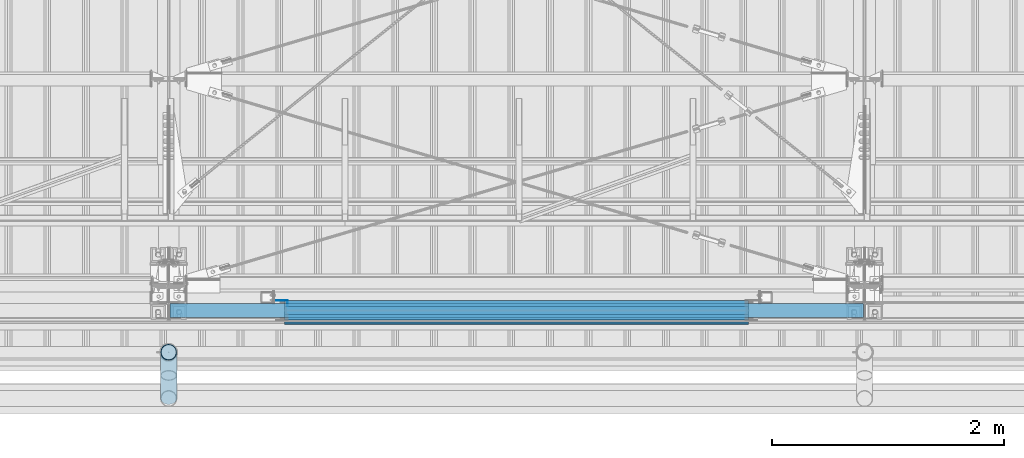
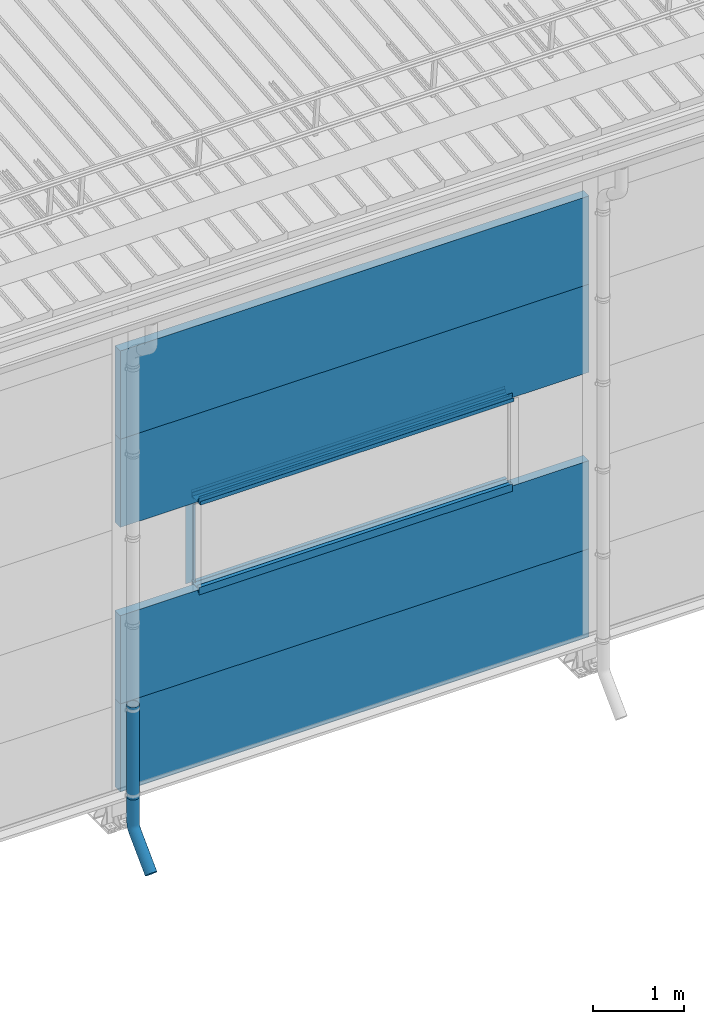
# One storey, part 30 of 709: 14 beams, 14 elements without a shape of their own.
"""IFC4 building model written with IfcOpenShell, lengths in millimetres."""

from ifc_helpers import new_model, entity, si_unit, direction, frame, origin_with_axes, place, context, subcontext, project, spatial, line, indexed_curve, outline, extrude, material, element, aggregate, save


model = new_model("IFC4")

# Units and contexts
model_context = context("Model", 3, precision=0.2, world=origin_with_axes(), true_north=direction((0.0, 1.0)))
body_context = subcontext(model_context, "Body", "Model", "MODEL_VIEW")
ifc_project = project(units=[si_unit("LENGTHUNIT", "METRE", prefix="MILLI"), si_unit("AREAUNIT", "SQUARE_METRE"), si_unit("VOLUMEUNIT", "CUBIC_METRE"), si_unit("MASSUNIT", "GRAM", prefix="KILO"), si_unit("TIMEUNIT", "SECOND"), si_unit("PLANEANGLEUNIT", "RADIAN"), si_unit("SOLIDANGLEUNIT", "STERADIAN"), si_unit("THERMODYNAMICTEMPERATUREUNIT", "DEGREE_CELSIUS"), si_unit("LUMINOUSINTENSITYUNIT", "LUMEN")], contexts=[model_context])

# Site, building, storey
site_placement = place(None, origin_with_axes())
site = spatial("IfcSite", under=ifc_project, at=site_placement, CompositionType="ELEMENT")
building_placement = place(site_placement, origin_with_axes())
building = spatial("IfcBuilding", under=site, at=building_placement, Name="Undefined", CompositionType="ELEMENT")
storey_placement = place(building_placement, origin_with_axes())
storey = spatial("IfcBuildingStorey", under=building, at=storey_placement, Name="Undefined", CompositionType="ELEMENT", Elevation=0.0)

# Assembly, beam
assembly_1_placement = place(storey_placement, frame((4010.0, -60.0, 895.0), z_axis=(0.0, 0.0, -1.0), x_axis=(1.0, 0.0, 0.0)))
assembly_1 = element("IfcElementAssembly", 1, at=assembly_1_placement, inside=storey)
ifc_material_1 = material(Name="Insulation", Category="Insulation")
beam_1_placement = place(assembly_1_placement, origin_with_axes())
beam_1 = element("IfcBeam", 2, at=beam_1_placement, material=ifc_material_1, ObjectType="P-107", context=body_context, shape_type="SolidModel", body=[
    extrude(outline(indexed_curve([(-595.0, -60.0), (595.0, -60.0), (595.0, 60.0), (-595.0, 60.0)], segments=[line(1, 2, 3, 4, 1)])), frame((0.0, 0.0, 0.0), z_axis=(-1.0, 0.0, 0.0), x_axis=(0.0, 0.0, 1.0)), (0.0, 0.0, -1.0), 5980.0),
])
aggregate(assembly_1, [beam_1])

assembly_2_placement = place(storey_placement, frame((4010.0, -60.0, 2085.0), z_axis=(0.0, 0.0, -1.0), x_axis=(1.0, 0.0, 0.0)))
assembly_2 = element("IfcElementAssembly", 3, at=assembly_2_placement, inside=storey)
beam_2_placement = place(assembly_2_placement, origin_with_axes())
beam_2 = element("IfcBeam", 4, at=beam_2_placement, material=ifc_material_1, ObjectType="P-107", context=body_context, shape_type="SolidModel", body=[
    extrude(outline(indexed_curve([(-595.0, -60.0), (595.0, -60.0), (595.0, 60.0), (-595.0, 60.0)], segments=[line(1, 2, 3, 4, 1)])), frame((0.0, 0.0, 0.0), z_axis=(-1.0, 0.0, 0.0), x_axis=(0.0, 0.0, 1.0)), (0.0, 0.0, -1.0), 5980.0),
])
aggregate(assembly_2, [beam_2])

assembly_3_placement = place(storey_placement, frame((4010.0, -60.0, 4465.0), z_axis=(0.0, 0.0, -1.0), x_axis=(1.0, 0.0, 0.0)))
assembly_3 = element("IfcElementAssembly", 5, at=assembly_3_placement, inside=storey)
beam_3_placement = place(assembly_3_placement, origin_with_axes())
beam_3 = element("IfcBeam", 6, at=beam_3_placement, material=ifc_material_1, ObjectType="P-107", context=body_context, shape_type="SolidModel", body=[
    extrude(outline(indexed_curve([(-595.0, -60.0), (595.0, -60.0), (595.0, 60.0), (-595.0, 60.0)], segments=[line(1, 2, 3, 4, 1)])), frame((0.0, 0.0, 0.0), z_axis=(-1.0, 0.0, 0.0), x_axis=(0.0, 0.0, 1.0)), (0.0, 0.0, -1.0), 5980.0),
])
aggregate(assembly_3, [beam_3])

assembly_4_placement = place(storey_placement, frame((4010.0, -60.0, 5655.0), z_axis=(0.0, 0.0, -1.0), x_axis=(1.0, 0.0, 0.0)))
assembly_4 = element("IfcElementAssembly", 7, at=assembly_4_placement, inside=storey)
beam_4_placement = place(assembly_4_placement, origin_with_axes())
beam_4 = element("IfcBeam", 8, at=beam_4_placement, material=ifc_material_1, ObjectType="P-107", context=body_context, shape_type="SolidModel", body=[
    extrude(outline(indexed_curve([(-595.0, -60.0), (595.0, -60.0), (595.0, 60.0), (-595.0, 60.0)], segments=[line(1, 2, 3, 4, 1)])), frame((0.0, 0.0, 0.0), z_axis=(-1.0, 0.0, 0.0), x_axis=(0.0, 0.0, 1.0)), (0.0, 0.0, -1.0), 5980.0),
])
aggregate(assembly_4, [beam_4])

assembly_5_placement = place(storey_placement, frame((5000.0, 1.0, 2725.0), z_axis=(0.0, 1.0, 0.0), x_axis=(1.0, 0.0, 0.0)))
assembly_5 = element("IfcElementAssembly", 9, at=assembly_5_placement, inside=storey)
ifc_material_2 = material(Name="Steel_Undefined", Category="STEEL")
beam_5_placement = place(assembly_5_placement, origin_with_axes())
beam_5 = element("IfcBeam", 10, at=beam_5_placement, material=ifc_material_2, context=body_context, shape_type="SolidModel", body=[
    extrude(outline(indexed_curve([(-25.0, -1.0), (25.0, -1.0), (25.0, 99.0), (23.0, 99.0), (23.0, 1.0), (-25.0, 1.0)], segments=[line(1, 2, 3, 4, 5, 6, 1)])), frame((0.0, 0.0, 0.0), z_axis=(-1.0, 0.0, 0.0), x_axis=(0.0, 0.0, 1.0)), (0.0, 0.0, -1.0), 4000.0),
])
aggregate(assembly_5, [beam_5])

assembly_6_placement = place(storey_placement, frame((9000.0, -60.0, 2680.0), z_axis=(0.0, 1.0, 0.0), x_axis=(-1.0, 0.0, 0.0)))
assembly_6 = element("IfcElementAssembly", 11, at=assembly_6_placement, inside=storey)
beam_6_placement = place(assembly_6_placement, origin_with_axes())
beam_6 = element("IfcBeam", 12, at=beam_6_placement, material=ifc_material_2, context=body_context, shape_type="SolidModel", body=[
    extrude(outline(indexed_curve([(-70.0, -25.0), (-68.0, -25.0), (-68.0, 23.0), (68.0, 23.0), (68.0, -25.0), (70.0, -25.0), (70.0, 25.0), (-70.0, 25.0)], segments=[line(1, 2, 3, 4, 5, 6, 7, 8, 1)])), frame((0.0, 0.0, 0.0), z_axis=(-1.0, 0.0, 0.0), x_axis=(0.0, 0.0, 1.0)), (0.0, 0.0, -1.0), 4000.0),
])
aggregate(assembly_6, [beam_6])

assembly_7_placement = place(storey_placement, frame((9000.0, -119.0, 2725.0), z_axis=(0.0, -1.0, 0.0), x_axis=(-1.0, 0.0, 0.0)))
assembly_7 = element("IfcElementAssembly", 13, at=assembly_7_placement, inside=storey)
beam_7_placement = place(assembly_7_placement, origin_with_axes())
beam_7 = element("IfcBeam", 14, at=beam_7_placement, material=ifc_material_2, context=body_context, shape_type="SolidModel", body=[
    extrude(outline(indexed_curve([(-25.0, -1.0), (25.0, -1.0), (25.0, 99.0), (23.0, 99.0), (23.0, 1.0), (-25.0, 1.0)], segments=[line(1, 2, 3, 4, 5, 6, 1)])), frame((0.0, 0.0, 0.0), z_axis=(-1.0, 0.0, 0.0), x_axis=(0.0, 0.0, 1.0)), (0.0, 0.0, -1.0), 4000.0),
])
aggregate(assembly_7, [beam_7])

assembly_8_placement = place(storey_placement, frame((9000.0, 1.0, 3845.0), z_axis=(0.0, 1.0, 0.0), x_axis=(-1.0, 0.0, 0.0)))
assembly_8 = element("IfcElementAssembly", 15, at=assembly_8_placement, inside=storey)
beam_8_placement = place(assembly_8_placement, origin_with_axes())
beam_8 = element("IfcBeam", 16, at=beam_8_placement, material=ifc_material_2, context=body_context, shape_type="SolidModel", body=[
    extrude(outline(indexed_curve([(-25.0, -1.0), (25.0, -1.0), (25.0, 99.0), (23.0, 99.0), (23.0, 1.0), (-25.0, 1.0)], segments=[line(1, 2, 3, 4, 5, 6, 1)])), frame((0.0, 0.0, 0.0), z_axis=(-1.0, 0.0, 0.0), x_axis=(0.0, 0.0, 1.0)), (0.0, 0.0, -1.0), 4000.0),
])
aggregate(assembly_8, [beam_8])

assembly_9_placement = place(storey_placement, frame((5000.0, -60.0, 3890.0), z_axis=(0.0, 1.0, 0.0), x_axis=(1.0, 0.0, 0.0)))
assembly_9 = element("IfcElementAssembly", 17, at=assembly_9_placement, inside=storey)
beam_9_placement = place(assembly_9_placement, origin_with_axes())
beam_9 = element("IfcBeam", 18, at=beam_9_placement, material=ifc_material_2, context=body_context, shape_type="SolidModel", body=[
    extrude(outline(indexed_curve([(-70.0, -25.0), (-68.0, -25.0), (-68.0, 23.0), (68.0, 23.0), (68.0, -25.0), (70.0, -25.0), (70.0, 25.0), (-70.0, 25.0)], segments=[line(1, 2, 3, 4, 5, 6, 7, 8, 1)])), frame((0.0, 0.0, 0.0), z_axis=(-1.0, 0.0, 0.0), x_axis=(0.0, 0.0, 1.0)), (0.0, 0.0, -1.0), 4000.0),
])
aggregate(assembly_9, [beam_9])

assembly_10_placement = place(storey_placement, frame((5000.0, -119.0, 3855.0), z_axis=(0.0, -1.0, 0.0), x_axis=(1.0, 0.0, 0.0)))
assembly_10 = element("IfcElementAssembly", 19, at=assembly_10_placement, inside=storey)
beam_10_placement = place(assembly_10_placement, origin_with_axes())
beam_10 = element("IfcBeam", 20, at=beam_10_placement, material=ifc_material_2, context=body_context, shape_type="SolidModel", body=[
    extrude(outline(indexed_curve([(-25.0, -1.0), (25.0, -1.0), (25.0, 99.0), (23.0, 99.0), (23.0, 1.0), (-25.0, 1.0)], segments=[line(1, 2, 3, 4, 5, 6, 1)])), frame((0.0, 0.0, 0.0), z_axis=(-1.0, 0.0, 0.0), x_axis=(0.0, 0.0, 1.0)), (0.0, 0.0, -1.0), 4000.0),
])
aggregate(assembly_10, [beam_10])

assembly_11_placement = place(storey_placement, frame((5000.0, -169.0, 3860.0), z_axis=(0.0, -1.0, 0.0), x_axis=(1.0, 0.0, 0.0)))
assembly_11 = element("IfcElementAssembly", 21, at=assembly_11_placement, inside=storey)
beam_11_placement = place(assembly_11_placement, origin_with_axes())
beam_11 = element("IfcBeam", 22, at=beam_11_placement, material=ifc_material_2, context=body_context, shape_type="SolidModel", body=[
    extrude(outline(indexed_curve([(-10.0, -1.0), (10.0, -1.0), (10.0, 49.0), (8.0, 49.0), (8.0, 1.0), (-10.0, 1.0)], segments=[line(1, 2, 3, 4, 5, 6, 1)])), frame((0.0, 0.0, 0.0), z_axis=(-1.0, 0.0, 0.0), x_axis=(0.0, 0.0, 1.0)), (0.0, 0.0, -1.0), 4000.0),
])
aggregate(assembly_11, [beam_11])

assembly_12_placement = place(storey_placement, frame((5025.0, 1.0, 3870.0), z_axis=(0.0, 1.0, 0.0), x_axis=(0.0, 0.0, -1.0)))
assembly_12 = element("IfcElementAssembly", 23, at=assembly_12_placement, inside=storey)
beam_12_placement = place(assembly_12_placement, origin_with_axes())
beam_12 = element("IfcBeam", 24, at=beam_12_placement, material=ifc_material_2, context=body_context, shape_type="SolidModel", body=[
    extrude(outline(indexed_curve([(-25.0, -1.0), (25.0, -1.0), (25.0, 99.0), (23.0, 99.0), (23.0, 1.0), (-25.0, 1.0)], segments=[line(1, 2, 3, 4, 5, 6, 1)])), frame((0.0, 0.0, 0.0), z_axis=(-1.0, 0.0, 0.0), x_axis=(0.0, 0.0, 1.0)), (0.0, 0.0, -1.0), 1170.0),
])
aggregate(assembly_12, [beam_12])

assembly_13_placement = place(storey_placement, frame((4000.0, -420.0, 1676.92297), z_axis=(0.0, 1.0, 0.0), x_axis=(0.0, 0.0, -1.0)))
assembly_13 = element("IfcElementAssembly", 25, at=assembly_13_placement, inside=storey)
beam_13_placement = place(assembly_13_placement, origin_with_axes())
beam_13 = element("IfcBeam", 26, at=beam_13_placement, material=ifc_material_2, ObjectType="614", context=body_context, shape_type="SolidModel", body=[
    extrude(outline(indexed_curve([(70.0, 0.0), (69.61653, 7.31699), (68.47033, 14.55382), (66.57396, 21.63119), (63.94818, 28.47157), (60.62178, 35.0), (56.63119, 41.14497), (52.02014, 46.83914), (46.83914, 52.02014), (41.14497, 56.63119), (35.0, 60.62178), (28.47157, 63.94818), (21.63119, 66.57396), (14.55382, 68.47033), (7.31699, 69.61653), (0.0, 70.0), (-7.31699, 69.61653), (-14.55382, 68.47033), (-21.63119, 66.57396), (-28.47157, 63.94818), (-35.0, 60.62178), (-41.14497, 56.63119), (-46.83914, 52.02014), (-52.02014, 46.83914), (-56.63119, 41.14497), (-60.62178, 35.0), (-63.94818, 28.47157), (-66.57396, 21.63119), (-68.47033, 14.55382), (-69.61653, 7.31699), (-70.0, 0.0), (-69.61653, -7.31699), (-68.47033, -14.55382), (-66.57396, -21.63119), (-63.94818, -28.47157), (-60.62178, -35.0), (-56.63119, -41.14497), (-52.02014, -46.83914), (-46.83914, -52.02014), (-41.14497, -56.63119), (-35.0, -60.62178), (-28.47157, -63.94818), (-21.63119, -66.57396), (-14.55382, -68.47033), (-7.31699, -69.61653), (0.0, -70.0), (7.31699, -69.61653), (14.55382, -68.47033), (21.63119, -66.57396), (28.47157, -63.94818), (35.0, -60.62178), (41.14497, -56.63119), (46.83914, -52.02014), (52.02014, -46.83914), (56.63119, -41.14497), (60.62178, -35.0), (63.94818, -28.47157), (66.57396, -21.63119), (68.47033, -14.55382), (69.61653, -7.31699)], segments=[line(1, 2, 3, 4, 5, 6, 7, 8, 9, 10, 11, 12, 13, 14, 15, 16, 17, 18, 19, 20, 21, 22, 23, 24, 25, 26, 27, 28, 29, 30, 31, 32, 33, 34, 35, 36, 37, 38, 39, 40, 41, 42, 43, 44, 45, 46, 47, 48, 49, 50, 51, 52, 53, 54, 55, 56, 57, 58, 59, 60, 1)]), holes=[indexed_curve([(65.0, 0.0), (64.64392, -6.79435), (63.57959, -13.51426), (61.81867, -20.0861), (59.38045, -26.43788), (56.29165, -32.5), (52.5861, -38.20604), (48.30441, -43.49349), (43.49349, -48.30441), (38.20604, -52.5861), (32.5, -56.29165), (26.43788, -59.38045), (20.0861, -61.81867), (13.51426, -63.57959), (6.79435, -64.64392), (0.0, -65.0), (-6.79435, -64.64392), (-13.51426, -63.57959), (-20.0861, -61.81867), (-26.43788, -59.38045), (-32.5, -56.29165), (-38.20604, -52.5861), (-43.49349, -48.30441), (-48.30441, -43.49349), (-52.5861, -38.20604), (-56.29165, -32.5), (-59.38045, -26.43788), (-61.81867, -20.0861), (-63.57959, -13.51426), (-64.64392, -6.79435), (-65.0, 0.0), (-64.64392, 6.79435), (-63.57959, 13.51426), (-61.81867, 20.0861), (-59.38045, 26.43788), (-56.29165, 32.5), (-52.5861, 38.20604), (-48.30441, 43.49349), (-43.49349, 48.30441), (-38.20604, 52.5861), (-32.5, 56.29165), (-26.43788, 59.38045), (-20.0861, 61.81867), (-13.51426, 63.57959), (-6.79435, 64.64392), (0.0, 65.0), (6.79435, 64.64392), (13.51426, 63.57959), (20.0861, 61.81867), (26.43788, 59.38045), (32.5, 56.29165), (38.20604, 52.5861), (43.49349, 48.30441), (48.30441, 43.49349), (52.5861, 38.20604), (56.29165, 32.5), (59.38045, 26.43788), (61.81867, 20.0861), (63.57959, 13.51426), (64.64392, 6.79435)], segments=[line(1, 2, 3, 4, 5, 6, 7, 8, 9, 10, 11, 12, 13, 14, 15, 16, 17, 18, 19, 20, 21, 22, 23, 24, 25, 26, 27, 28, 29, 30, 31, 32, 33, 34, 35, 36, 37, 38, 39, 40, 41, 42, 43, 44, 45, 46, 47, 48, 49, 50, 51, 52, 53, 54, 55, 56, 57, 58, 59, 60, 1)])]), frame((0.0, 0.0, 0.0), z_axis=(-1.0, 0.0, 0.0), x_axis=(0.0, 0.0, 1.0)), (0.0, 0.0, -1.0), 1250.0),
])
aggregate(assembly_13, [beam_13])

assembly_14_placement = place(storey_placement, frame((4000.0, -420.0, 526.92297), z_axis=(-1.0, 0.0, 0.0), x_axis=(0.0, 0.0, -1.0)))
assembly_14 = element("IfcElementAssembly", 27, at=assembly_14_placement, inside=storey)
beam_14_placement = place(assembly_14_placement, origin_with_axes())
beam_14 = element("IfcBeam", 28, at=beam_14_placement, material=ifc_material_2, ObjectType="617", context=body_context, shape_type="SolidModel", body=[
    entity("IfcSweptDiskSolid", entity("IfcIndexedPolyCurve", entity("IfcCartesianPointList3D", [[0.0, 0.0, 0.0], [448.2233, 0.0, 0.0], [496.05873, 9.51506, 0.0], [536.61165, 36.61165, 0.0], [900.0, 400.0, 0.0]]), [entity("IfcLineIndex", [1, 2]), entity("IfcArcIndex", [2, 3, 4]), entity("IfcLineIndex", [4, 5])]), 70.0, 65.0),
])
aggregate(assembly_14, [beam_14])

save(model, "model.ifc")
